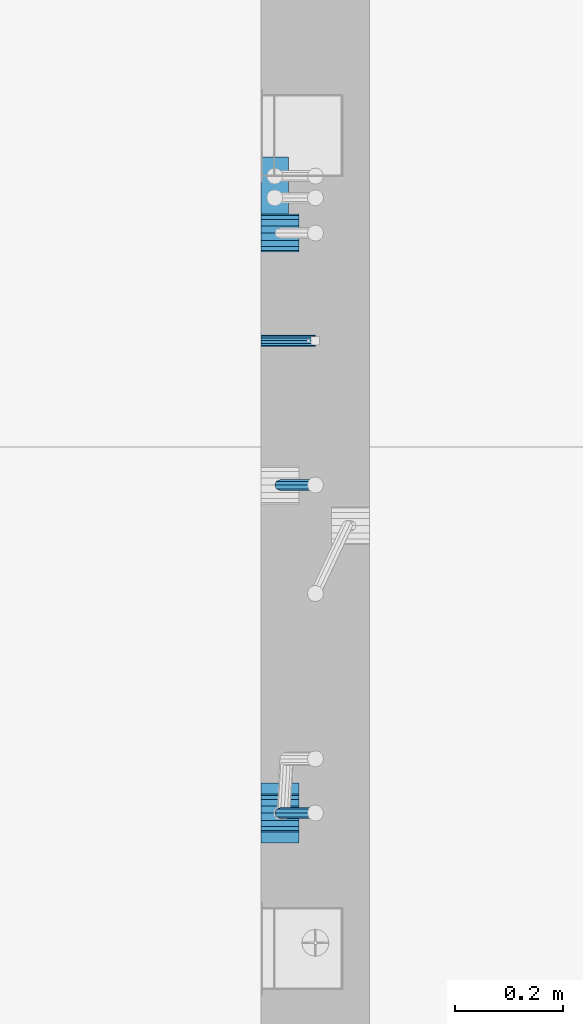
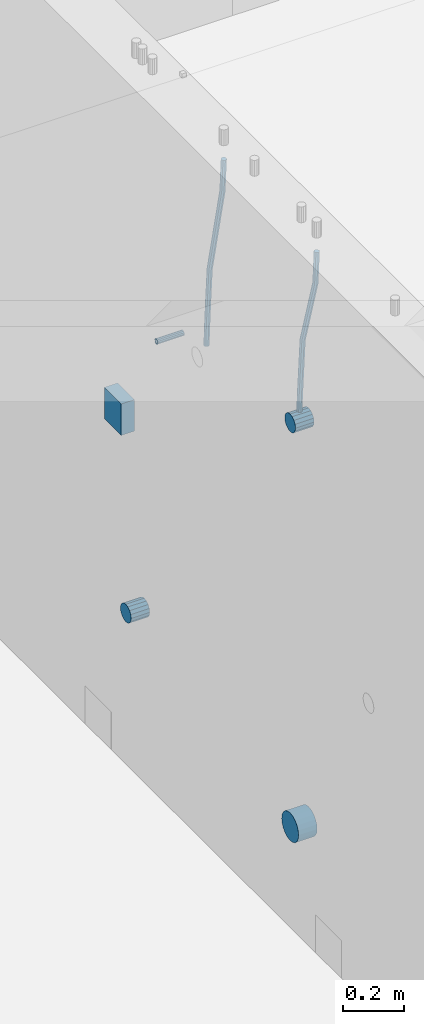
# One storey, part 126 of 325: 7 beams, 2 elements without a shape of their own.
"""IFC2X3 building model written with IfcOpenShell, lengths in millimetres."""

from ifc_helpers import new_model, si_unit, frame, origin_with_axes, place, context, subcontext, project, spatial, faceted_brep, material, type_object, element, aggregate, save


model = new_model("IFC2X3")

# Units and contexts
model_context = context("Model", 3, precision=1e-05, world=origin_with_axes())
body_context = subcontext(model_context, "Body", "Model", "MODEL_VIEW")
ifc_project = project(units=[si_unit("LENGTHUNIT", "METRE", prefix="MILLI"), si_unit("AREAUNIT", "SQUARE_METRE"), si_unit("VOLUMEUNIT", "CUBIC_METRE"), si_unit("MASSUNIT", "GRAM", prefix="KILO"), si_unit("TIMEUNIT", "SECOND"), si_unit("PLANEANGLEUNIT", "RADIAN"), si_unit("SOLIDANGLEUNIT", "STERADIAN"), si_unit("THERMODYNAMICTEMPERATUREUNIT", "DEGREE_CELSIUS"), si_unit("LUMINOUSINTENSITYUNIT", "LUMEN")], contexts=[model_context])

# Site, building, storey
site_placement = place(None, origin_with_axes())
site = spatial("IfcSite", under=ifc_project, at=site_placement, CompositionType="ELEMENT")
building_placement = place(site_placement, origin_with_axes())
building = spatial("IfcBuilding", under=site, at=building_placement, CompositionType="ELEMENT")
storey_placement = place(building_placement, origin_with_axes())
storey = spatial("IfcBuildingStorey", under=building, at=storey_placement, Name="1", CompositionType="ELEMENT", Elevation=0.0)

# Assemblies, beams
assembly_1_placement = place(storey_placement, origin_with_axes())
assembly_1 = element("IfcElementAssembly", 1, at=assembly_1_placement, inside=storey, AssemblyPlace="NOTDEFINED", PredefinedType="REINFORCEMENT_UNIT")
assembly_2_placement = place(assembly_1_placement, origin_with_axes())
assembly_2 = element("IfcElementAssembly", 2, at=assembly_2_placement, Name="Steel Assembly", AssemblyPlace="NOTDEFINED", PredefinedType="RIGID_FRAME")
ifc_material_1 = material(Name="STEEL/Steel_Undefined")
beam_type_1 = type_object("IfcBeamType", PredefinedType="NOTDEFINED")
beam_1_placement = place(assembly_2_placement, frame((21710.0, 11376.2997839591, 83555.0), z_axis=(0.0, 1.0, 0.0), x_axis=(1.0, 0.0, 0.0)))
beam_1 = element("IfcBeam", 3, at=beam_1_placement, type_object=beam_type_1, material=ifc_material_1, Name="M16", context=body_context, shape_type="Brep", body=[
    faceted_brep([(0.0, -8.49999999999272, -1.45519152283669e-11), (0.0, -7.36121593215648, 4.24999999998545), (100.000000000262, -7.36121593215648, 4.24999999998545), (100.000000000262, -8.49999999999272, -1.45519152283669e-11), (0.0, -4.24999999998545, 7.36121593216376), (100.000000000262, -4.24999999998545, 7.36121593216376), (0.0, 1.45519152283669e-11, 8.49999999998545), (100.000000000262, 1.45519152283669e-11, 8.49999999998545), (0.0, 4.25000000001455, 7.36121593216376), (100.000000000262, 4.25000000001455, 7.36121593216376), (0.0, 7.36121593217104, 4.24999999998545), (100.000000000262, 7.36121593217104, 4.24999999998545), (0.0, 8.50000000000728, 0.0), (100.000000000262, 8.50000000000728, 0.0), (0.0, 7.36121593217104, -4.25000000001455), (100.000000000262, 7.36121593217104, -4.25000000001455), (0.0, 4.25000000000728, -7.36121593219286), (100.000000000262, 4.25000000000728, -7.36121593219286), (0.0, 7.27595761418343e-12, -8.5), (100.000000000262, 7.27595761418343e-12, -8.5), (0.0, -4.24999999999272, -7.36121593217831), (100.000000000262, -4.24999999999272, -7.36121593217831), (0.0, -7.36121593215648, -4.25), (100.000000000262, -7.36121593215648, -4.25), (0.0, -10.4999999999927, -1.45519152283669e-11), (0.0, -9.09326673972828, -5.25000000001455), (100.000000000262, -9.09326673972828, -5.25000000001455), (100.000000000262, -10.4999999999927, -1.45519152283669e-11), (0.0, -5.24999999998545, -9.09326673974283), (100.000000000262, -5.24999999998545, -9.09326673974283), (0.0, 7.27595761418343e-12, -10.5), (100.000000000262, 7.27595761418343e-12, -10.5), (0.0, 5.25000000001455, -9.09326673975738), (100.000000000262, 5.25000000001455, -9.09326673975738), (0.0, 9.09326673975011, -5.25000000001455), (100.000000000262, 9.09326673975011, -5.25000000001455), (0.0, 10.5000000000073, -1.45519152283669e-11), (100.000000000262, 10.5000000000073, -1.45519152283669e-11), (0.0, 9.09326673975011, 5.25), (100.000000000262, 9.09326673975011, 5.25), (0.0, 5.25000000000728, 9.09326673972828), (100.000000000262, 5.25000000000728, 9.09326673972828), (0.0, 1.45519152283669e-11, 10.4999999999854), (100.000000000262, 1.45519152283669e-11, 10.4999999999854), (0.0, -5.24999999999272, 9.09326673972828), (100.000000000262, -5.24999999999272, 9.09326673972828), (0.0, -9.09326673972828, 5.24999999998545), (100.000000000262, -9.09326673972828, 5.24999999998545)], [[[0, 1, 2, 3]], [[1, 4, 5, 2]], [[4, 6, 7, 5]], [[6, 8, 9, 7]], [[8, 10, 11, 9]], [[10, 12, 13, 11]], [[12, 14, 15, 13]], [[14, 16, 17, 15]], [[16, 18, 19, 17]], [[18, 20, 21, 19]], [[20, 22, 23, 21]], [[22, 0, 3, 23]], [[24, 25, 26, 27]], [[25, 28, 29, 26]], [[28, 30, 31, 29]], [[30, 32, 33, 31]], [[32, 34, 35, 33]], [[34, 36, 37, 35]], [[36, 38, 39, 37]], [[38, 40, 41, 39]], [[40, 42, 43, 41]], [[42, 44, 45, 43]], [[44, 46, 47, 45]], [[46, 24, 27, 47]], [[29, 31, 33, 35, 37, 39, 41, 43, 45, 47, 27, 26], [5, 7, 9, 11, 13, 15, 17, 19, 21, 23, 3, 2]], [[46, 44, 42, 40, 38, 36, 34, 32, 30, 28, 25, 24], [22, 20, 18, 16, 14, 12, 10, 8, 6, 4, 1, 0]]]),
])
aggregate(assembly_2, [beam_1])
ifc_material_2 = material()
beam_type_2 = type_object("IfcBeamType", Name="D20", PredefinedType="NOTDEFINED")
beam_2_placement = place(assembly_1_placement, frame((21744.9999977209, 10504.9999999961, 83795.0), z_axis=(0.999642804629538, 0.000205762999925497, -0.0267249099901003), x_axis=(0.0267249109941254, -4.30000210532798e-08, 0.999642825779465)))
beam_2 = element("IfcBeam", 4, at=beam_2_placement, type_object=beam_type_2, material=ifc_material_2, Name="JM20", ObjectType="D20", context=body_context, shape_type="Brep", body=[
    faceted_brep([(0.0, -10.0, 0.0), (-4.19531716033816e-08, -7.07106781186667, -7.07106781187031), (60.3902110151248, -7.07106779622882, -7.07106780570393), (60.3902110191848, -9.99999998436397, 6.15546014159918e-09), (0.0, 0.0, -10.0), (60.3902110119234, 1.56360329128802e-08, -9.99999999383726), (4.196772351861e-08, 7.07106781186303, -7.07106781186667), (60.3902110114723, 7.07106782750088, -7.07106780570757), (0.0, 10.0, 0.0), (60.3902110140189, 10.000000015636, 6.15909812040627e-09), (4.196772351861e-08, 7.07106781185939, 7.07106781185939), (60.3902110180788, 7.07106782750088, 7.07106781802213), (0.0, 0.0, 10.0), (60.3902110212803, 1.56378519022837e-08, 10.0000000061627), (-4.19531716033816e-08, -7.07106781187031, 7.07106781185939), (60.3902110217459, -7.07106779622882, 7.07106781802213), (61.0636251037213, -7.07106779605601, -7.07106780563481), (60.991799419251, -9.99999998403655, 6.21366780251265e-09), (61.0933608038758, 1.58179318532348e-08, -9.99999999376814), (61.0635953103047, 7.07106782767551, -7.07106780563481), (60.9917724058905, 10.0000000159635, 6.21366780251265e-09), (60.9199467214348, 7.07106782763913, 7.07106781808034), (60.8902110212803, 1.57651811605319e-08, 10.0000000062137), (60.919976514866, -7.07106779609421, 7.07106781808034), (61.736900248201, -7.07106495914195, -7.05738882369405), (61.5932788141945, -9.99999744984598, 0.0122201548947487), (61.7963655163912, 2.97800033877138e-06, -9.98571699394597), (61.7368406711612, 7.07107066446406, -7.05738942880998), (61.5931945595512, 10.0000025499758, 0.0122192991293559), (61.4495731255302, 7.07107005927173, 7.0818282777218), (61.3901078573399, 2.12213126360439e-06, 10.0101564479701), (61.4496327025554, -7.07106556433428, 7.08182888283409), (278.724613209561, -7.07015065944142, -2.64883307638229), (278.580991775569, -9.99908315014545, 4.42077590220288), (278.78407847778, 0.000917277700864361, -5.57716124663784), (278.724553632535, 7.07198496416277, -2.64883368149822), (278.580907520925, 10.0009168496781, 4.42077504644112), (278.437286086933, 7.07198435897226, 11.4903840250299), (278.377820818714, 0.000916421833608183, 14.4187121952782), (278.437345663944, -7.07015126463193, 11.4903846301422), (280.757740145142, -7.07014209265617, -2.60752588292962), (279.97914288567, -9.99907725889352, 4.4491822438722), (281.080112136013, 0.000926952270674519, -5.53051255744504), (280.757417718196, 7.07199352984026, -2.60753182838744), (279.978686905117, 10.0009227393621, 4.44917383572465), (279.200089645645, 7.0719875731229, 11.5058819625192), (278.877717654759, 0.000918528197871638, 14.4288686370419), (279.200412072576, -7.07014804937353, 11.5058879079807), (282.750959243713, -7.07005867588668, -2.20455064874841), (281.349849970706, -9.99901989442333, 4.72630231008952), (283.331077414448, 0.00102115578738449, -5.07542798552822), (282.750379126286, 7.07207693582313, -2.20460869228191), (281.349029560777, 10.0009800885819, 4.72622022413998), (279.947920287756, 7.07201887003976, 11.6570731829706), (279.367802117034, 0.000939038367505418, 14.5279505197614), (279.948500405197, -7.07011674167188, 11.6571312265078), (490.42756900216, -7.06136735270411, 39.782068138702), (489.026459729153, -9.99032857123893, 46.7129210975436), (491.007687172896, 0.00971247897177818, 36.9111908019222), (490.426988884734, 7.08076825901298, 39.7820100951685), (489.02563931921, 10.0096714117662, 46.7128390115868), (487.624530046218, 7.08071019322961, 53.6436919704247), (487.044411875468, 0.0096303615537181, 56.5145693072081), (487.625110163644, -7.06142541848567, 53.6437500139618), (491.139936791646, -7.06133753991526, 39.9260897251916), (490.366909417033, -9.99027247305094, 46.9839239327412), (491.497771635157, 0.00973298914141196, 37.0102726846344), (491.230799149358, 7.08080189869361, 39.9445188880345), (490.495408195638, 10.0097329219989, 47.0099867047757), (489.722380821026, 7.08079798886138, 54.0678209123216), (489.3645459775, 0.00972745980288892, 56.9836379528824), (489.631518463313, -7.06134144974749, 54.0493917494787), (491.866591294849, -7.07081326331172, 39.9357607788479), (491.734242157807, -10.008102771757, 47.0021217808862), (491.997684863585, 0.00321401835935831, 37.0169260358998), (492.050730029368, 7.07010983225518, 39.955431358132), (491.994653653514, 9.99018245447223, 47.0299401808879), (491.862304516457, 7.05289294603062, 54.0963011829335), (491.731210947721, -0.0211343356422731, 57.0151359258853), (491.678165781937, -7.08803014953628, 54.0766306036494), (512.839658019177, -7.34430634461387, 40.2148915801045), (512.707308882134, -10.2815958530537, 47.2812525821391), (512.970751587927, -0.270279062942791, 37.2960568371527), (513.023796753681, 6.79661675095485, 40.2345621593813), (512.967720377841, 9.7166893731719, 47.3090709821408), (512.835371240784, 6.77939986473211, 54.3754319841792), (512.704277672048, -0.294627416940784, 57.2942667271309), (512.651232506279, -7.36152323083843, 54.3557614048987), (513.475023168634, -7.35259163615956, 40.2233476626352), (513.367394028246, -10.2902034984181, 47.2900376634097), (513.548964110931, -0.277819072547572, 37.3037522746854), (513.54590325398, 6.78980837536619, 40.2415108811765), (513.467633606255, 9.71017040238803, 47.3157243334063), (513.360004465882, 6.77255854013129, 54.3824143341844), (513.28606352357, -0.302214023480701, 57.3020097221342), (513.289124380535, -7.36984147139265, 54.3642511156468), (514.110442121717, -7.35071708105352, 40.2316099536038), (514.027534909808, -10.2882349910469, 47.298629034136), (514.127225867254, -0.276123320652914, 37.311252921696), (514.068054455944, 6.79134521359629, 40.248263480742), (513.967589697961, 9.71166130597521, 47.3221806780894), (513.884682486052, 6.77414339598363, 54.3891997586288), (513.8678987405, -0.300450364420612, 57.309556790533), (513.927070151825, -7.36791889866981, 54.3725462314869), (614.131230002764, -7.05245493793518, 41.5289880054152), (614.048322790841, -9.98997284792858, 48.596007085951), (614.148013748316, 0.022138822467241, 38.608630973511), (614.088842336976, 7.08960735671644, 41.5456415325607), (613.988377579022, 10.0099234490935, 48.6195587299044), (613.905470367114, 7.07240553910196, 55.6865778104475), (613.888686621562, -0.00218822130045737, 58.6069348423516), (613.947858032887, -7.06965675554966, 55.6699242832983)], [[[0, 1, 2, 3]], [[1, 4, 5, 2]], [[4, 6, 7, 5]], [[6, 8, 9, 7]], [[8, 10, 11, 9]], [[10, 12, 13, 11]], [[12, 14, 15, 13]], [[14, 0, 3, 15]], [[14, 12, 10, 8, 6, 4, 1, 0]], [[3, 2, 16, 17]], [[2, 5, 18, 16]], [[5, 7, 19, 18]], [[7, 9, 20, 19]], [[9, 11, 21, 20]], [[11, 13, 22, 21]], [[13, 15, 23, 22]], [[15, 3, 17, 23]], [[17, 16, 24, 25]], [[16, 18, 26, 24]], [[18, 19, 27, 26]], [[19, 20, 28, 27]], [[20, 21, 29, 28]], [[21, 22, 30, 29]], [[22, 23, 31, 30]], [[23, 17, 25, 31]], [[25, 24, 32, 33]], [[24, 26, 34, 32]], [[26, 27, 35, 34]], [[27, 28, 36, 35]], [[28, 29, 37, 36]], [[29, 30, 38, 37]], [[30, 31, 39, 38]], [[31, 25, 33, 39]], [[33, 32, 40, 41]], [[32, 34, 42, 40]], [[34, 35, 43, 42]], [[35, 36, 44, 43]], [[36, 37, 45, 44]], [[37, 38, 46, 45]], [[38, 39, 47, 46]], [[39, 33, 41, 47]], [[41, 40, 48, 49]], [[40, 42, 50, 48]], [[42, 43, 51, 50]], [[43, 44, 52, 51]], [[44, 45, 53, 52]], [[45, 46, 54, 53]], [[46, 47, 55, 54]], [[47, 41, 49, 55]], [[49, 48, 56, 57]], [[48, 50, 58, 56]], [[50, 51, 59, 58]], [[51, 52, 60, 59]], [[52, 53, 61, 60]], [[53, 54, 62, 61]], [[54, 55, 63, 62]], [[55, 49, 57, 63]], [[57, 56, 64, 65]], [[56, 58, 66, 64]], [[58, 59, 67, 66]], [[59, 60, 68, 67]], [[60, 61, 69, 68]], [[61, 62, 70, 69]], [[62, 63, 71, 70]], [[63, 57, 65, 71]], [[65, 64, 72, 73]], [[64, 66, 74, 72]], [[66, 67, 75, 74]], [[67, 68, 76, 75]], [[68, 69, 77, 76]], [[69, 70, 78, 77]], [[70, 71, 79, 78]], [[71, 65, 73, 79]], [[73, 72, 80, 81]], [[72, 74, 82, 80]], [[74, 75, 83, 82]], [[75, 76, 84, 83]], [[76, 77, 85, 84]], [[77, 78, 86, 85]], [[78, 79, 87, 86]], [[79, 73, 81, 87]], [[81, 80, 88, 89]], [[80, 82, 90, 88]], [[82, 83, 91, 90]], [[83, 84, 92, 91]], [[84, 85, 93, 92]], [[85, 86, 94, 93]], [[86, 87, 95, 94]], [[87, 81, 89, 95]], [[89, 88, 96, 97]], [[88, 90, 98, 96]], [[90, 91, 99, 98]], [[91, 92, 100, 99]], [[92, 93, 101, 100]], [[93, 94, 102, 101]], [[94, 95, 103, 102]], [[95, 89, 97, 103]], [[97, 96, 104, 105]], [[96, 98, 106, 104]], [[98, 99, 107, 106]], [[99, 100, 108, 107]], [[100, 101, 109, 108]], [[101, 102, 110, 109]], [[102, 103, 111, 110]], [[103, 97, 105, 111]], [[106, 107, 108, 109, 110, 111, 105, 104]]]),
])
beam_3_placement = place(assembly_1_placement, frame((21744.9999977209, 11109.9999999961, 83690.0), z_axis=(0.999642804629538, 0.000205762999925497, -0.0267249099901003), x_axis=(0.0267249109941254, -4.30000210532798e-08, 0.999642825779465)))
beam_3 = element("IfcBeam", 5, at=beam_3_placement, type_object=beam_type_2, material=ifc_material_2, Name="JM20", ObjectType="D20", context=body_context, shape_type="Brep", body=[
    faceted_brep([(0.0, -10.0, 0.0), (-4.19531716033816e-08, -7.07106781186667, -7.07106781187031), (60.4266690400545, -7.0710677960451, -7.07106780570757), (60.4266690441291, -9.99999998418934, 6.15546014159918e-09), (0.0, 0.0, -10.0), (60.426669036824, 1.58106558956206e-08, -9.99999999384454), (4.196772351861e-08, 7.07106781186303, -7.07106781186667), (60.4266690363438, 7.07106782768096, -7.07106780570757), (0.0, 10.0, 0.0), (60.4266690388904, 10.0000000158179, 6.15182216279209e-09), (4.196772351861e-08, 7.07106781185939, 7.07106781185939), (60.4266690429649, 7.07106782768096, 7.07106781802577), (0.0, 0.0, 10.0), (60.4266690461809, 1.58179318532348e-08, 10.0000000061555), (-4.19531716033816e-08, -7.07106781187031, 7.07106781185939), (60.4266690466611, -7.07106779605238, 7.07106781802213), (61.0378400410118, -7.07106779588503, -7.07106780564936), (60.991799419251, -9.99999998403655, 6.21366780251265e-09), (61.0569027789461, 1.5985278878361e-08, -9.99999999378269), (61.0378209396877, 7.07106782784831, -7.07106780564936), (60.9917724058905, 10.0000000159635, 6.21366780251265e-09), (60.9457317841297, 7.07106782781193, 7.0710678180767), (60.9266690461809, 1.59488990902901e-08, 10.0000000062028), (60.9457508854539, -7.07106779591413, 7.0710678180767), (61.6489592143771, -7.07106614513759, -7.06310863441468), (61.5568818710308, -9.9999984576425, 0.00735959856683621), (61.6870830769039, 1.71821739058942e-06, -9.99179257185824), (61.6489210170112, 7.07106947854481, -7.06310888312146), (61.556827851804, 10.0000015422847, 0.00735924683976918), (61.4647505084577, 7.07106922979438, 7.07782747982128), (61.4266266459163, 1.36643211590126e-06, 10.0065114172685), (61.464788705809, -7.07106639389531, 7.07782772852806), (176.543135720174, -7.07075579406956, -5.56673531796696), (176.451058376813, -9.99968810657447, 1.50373291501455), (176.581259582701, 0.000312069292704109, -8.49541925541052), (176.543097522794, 7.07137982961285, -5.56673556667374), (176.451004357587, 10.00031189336, 1.50373256329476), (176.35892701424, 7.07137958085514, 8.57420079627263), (176.320803151699, 0.000311717507429421, 11.5028847337162), (176.358965211621, -7.07075604281999, 8.57420104497578), (177.098753836006, -7.07075429323595, -5.55949898843028), (176.98362511232, -9.99968666800123, 1.510669025065), (177.146421932586, 0.000313595905026887, -8.48805862247536), (177.098706077581, 7.07138133041735, -5.55949936166144), (176.983557571715, 10.0003133318824, 1.51066849724157), (176.868428848029, 7.07138095712435, 8.58083651073321), (176.820760751449, 0.000313067976094317, 11.5093961447819), (176.868476606425, -7.07075466652896, 8.58083688396073), (177.654312950661, -7.07075204110879, -5.54863964998367), (177.516135294456, -9.99968450931192, 1.52107783331303), (177.711524267797, 0.000315886711177882, -8.47701274570863), (177.654255632195, 7.07138358250813, -5.54864021007961), (177.516054233929, 10.0003154905207, 1.5210770412159), (177.377876577739, 7.0713830223176, 8.59079452451624), (177.320665260588, 0.000315094497636892, 11.5191676202448), (177.377933896176, -7.07075260129932, 8.59079508461218), (299.029771459231, -7.07026000924998, -3.17615191846562), (298.89159380304, -9.99919247745311, 3.89356556482744), (299.086982776382, 0.00080791857362783, -6.10452501419059), (299.029714140794, 7.07187561436331, -3.1761524785652), (298.891512742513, 10.0008075223832, 3.89356477273031), (298.753335086294, 7.07187505418005, 10.963282256027), (298.696123769172, 0.000807126352810883, 13.891655351752), (298.75339240476, -7.07026056943323, 10.963282816123), (300.5204182054, -7.07025396646532, -3.14701471758235), (299.971932015731, -9.99918809797782, 3.91468259446992), (300.747514543924, 0.000814650038591935, -6.07206712448169), (300.520191076153, 7.07188165646039, -3.14701859691559), (299.971610806504, 10.0008119008835, 3.91467710826691), (299.423124616849, 7.0718777693728, 10.9763744203192), (299.196028278326, 0.000809152865258511, 13.9014268272185), (299.423351746067, -7.0702578535529, 10.9763782996524), (301.997683885507, -7.07021227996847, -2.94561261413764), (301.042572372782, -9.99915788591352, 4.06064768581928), (302.393140241125, 0.000861087435623631, -5.84771176216236), (301.997288469822, 7.07192333820967, -2.94563943669345), (301.042013170576, 10.0008421062339, 4.0606097529926), (300.086901657865, 7.07189650029068, 11.0668700529459), (299.691445302247, 0.000823132886580424, 13.9689692009706), (300.087297073522, -7.07023911788747, 11.066896875509), (595.247547294217, -7.06193715364316, 37.0344262651415), (594.292435781506, -9.99088275958638, 44.0406865650948), (595.643003649835, 0.00913621376093943, 34.1323271171168), (595.247151878561, 7.08019846453499, 37.0343994425784), (594.291876579315, 10.0091172325574, 44.0406486322681), (593.336765066575, 7.08017162661235, 51.0469089322251), (592.941308710972, 0.00909825921189622, 53.9490080802498), (593.337160482261, -7.06196399156397, 51.0469357547881), (595.874536898147, -7.0619194608189, 37.1199065052715), (595.328959329563, -9.99085351025315, 44.1820003623798), (596.138420673757, 0.00915019377680437, 34.1998694908689), (595.966031119533, 7.08021875036138, 37.132407399582), (595.458351698282, 10.0091501489569, 44.1996792966529), (594.912774129698, 7.08021609952084, 51.2617731537612), (594.648890354089, 0.00914644492513617, 54.1818101681638), (594.821279908327, -7.06192211166126, 51.2492722594543), (596.507216806087, -7.07016973634745, 37.1283268498955), (596.374889946004, -10.0044926596274, 44.1959206657302), (596.638333902185, 0.00263122293472406, 34.2065228421343), (596.691434617649, 7.07075934023669, 37.1420618035991), (596.635413273558, 9.99380102503346, 44.2153448235404), (596.503086413475, 7.05947810175894, 51.2829386393751), (596.371969317406, -0.0133228575232351, 54.2047426471363), (596.318868601928, -7.08145097482702, 51.2692036856752), (617.802075790198, -7.34785905717763, 37.4117403882592), (617.669748930144, -10.282181980454, 44.4793342040939), (617.933192886281, -0.275058097895453, 34.4899363805016), (617.98629360176, 6.79307001940651, 37.4254753419664), (617.930272257669, 9.7161117042051, 44.498758361904), (617.797945397615, 6.78178878092876, 51.5663521777387), (617.666828301532, -0.291012178353412, 54.4881561855073), (617.613727586038, -7.35914029565538, 51.5526172240352), (618.437465979412, -7.3561446753265, 37.4201968040506), (618.329835563593, -10.2907896452944, 44.488119305166), (618.51143976918, -0.28259855563374, 34.4976322753282), (618.508424090105, 6.78626133094076, 37.4324243830088), (618.430185486082, 9.70959273336121, 44.5054117131695), (618.322555070263, 6.77494776339336, 51.5733342142812), (618.248581280495, -0.298598356299408, 54.4958987430036), (618.25159695957, -7.36745824287755, 51.5611066353231), (619.072909978044, -7.35426965608167, 37.428459048002), (618.989977939549, -10.2888211210229, 44.4967101569127), (619.089735886533, -0.2809021629364, 34.5051333804877), (619.030599275982, 6.78779861257681, 37.4391776831617), (618.930141570861, 9.7110836245156, 44.5118685961243), (618.847209532338, 6.77653215957434, 51.5801197050387), (618.830383623877, -0.296835333569106, 54.503445372553), (618.889520234414, -7.36553610908049, 51.569401069879), (719.093697115357, -7.05600751202655, 38.7258370901727), (719.010765076877, -9.9905589769678, 45.7940881990799), (719.110523023846, 0.017359981116897, 35.8025114226548), (719.051386413325, 7.08606075662829, 38.7365557253288), (718.950928708175, 10.0093457685707, 45.809246638295), (718.86799666968, 7.07479430362946, 52.8774977472058), (718.851170761191, 0.00142681048419036, 55.8008234147201), (718.910307371727, -7.06727396502902, 52.8667791120424)], [[[0, 1, 2, 3]], [[1, 4, 5, 2]], [[4, 6, 7, 5]], [[6, 8, 9, 7]], [[8, 10, 11, 9]], [[10, 12, 13, 11]], [[12, 14, 15, 13]], [[14, 0, 3, 15]], [[14, 12, 10, 8, 6, 4, 1, 0]], [[3, 2, 16, 17]], [[2, 5, 18, 16]], [[5, 7, 19, 18]], [[7, 9, 20, 19]], [[9, 11, 21, 20]], [[11, 13, 22, 21]], [[13, 15, 23, 22]], [[15, 3, 17, 23]], [[17, 16, 24, 25]], [[16, 18, 26, 24]], [[18, 19, 27, 26]], [[19, 20, 28, 27]], [[20, 21, 29, 28]], [[21, 22, 30, 29]], [[22, 23, 31, 30]], [[23, 17, 25, 31]], [[25, 24, 32, 33]], [[24, 26, 34, 32]], [[26, 27, 35, 34]], [[27, 28, 36, 35]], [[28, 29, 37, 36]], [[29, 30, 38, 37]], [[30, 31, 39, 38]], [[31, 25, 33, 39]], [[33, 32, 40, 41]], [[32, 34, 42, 40]], [[34, 35, 43, 42]], [[35, 36, 44, 43]], [[36, 37, 45, 44]], [[37, 38, 46, 45]], [[38, 39, 47, 46]], [[39, 33, 41, 47]], [[41, 40, 48, 49]], [[40, 42, 50, 48]], [[42, 43, 51, 50]], [[43, 44, 52, 51]], [[44, 45, 53, 52]], [[45, 46, 54, 53]], [[46, 47, 55, 54]], [[47, 41, 49, 55]], [[49, 48, 56, 57]], [[48, 50, 58, 56]], [[50, 51, 59, 58]], [[51, 52, 60, 59]], [[52, 53, 61, 60]], [[53, 54, 62, 61]], [[54, 55, 63, 62]], [[55, 49, 57, 63]], [[57, 56, 64, 65]], [[56, 58, 66, 64]], [[58, 59, 67, 66]], [[59, 60, 68, 67]], [[60, 61, 69, 68]], [[61, 62, 70, 69]], [[62, 63, 71, 70]], [[63, 57, 65, 71]], [[65, 64, 72, 73]], [[64, 66, 74, 72]], [[66, 67, 75, 74]], [[67, 68, 76, 75]], [[68, 69, 77, 76]], [[69, 70, 78, 77]], [[70, 71, 79, 78]], [[71, 65, 73, 79]], [[73, 72, 80, 81]], [[72, 74, 82, 80]], [[74, 75, 83, 82]], [[75, 76, 84, 83]], [[76, 77, 85, 84]], [[77, 78, 86, 85]], [[78, 79, 87, 86]], [[79, 73, 81, 87]], [[81, 80, 88, 89]], [[80, 82, 90, 88]], [[82, 83, 91, 90]], [[83, 84, 92, 91]], [[84, 85, 93, 92]], [[85, 86, 94, 93]], [[86, 87, 95, 94]], [[87, 81, 89, 95]], [[89, 88, 96, 97]], [[88, 90, 98, 96]], [[90, 91, 99, 98]], [[91, 92, 100, 99]], [[92, 93, 101, 100]], [[93, 94, 102, 101]], [[94, 95, 103, 102]], [[95, 89, 97, 103]], [[97, 96, 104, 105]], [[96, 98, 106, 104]], [[98, 99, 107, 106]], [[99, 100, 108, 107]], [[100, 101, 109, 108]], [[101, 102, 110, 109]], [[102, 103, 111, 110]], [[103, 97, 105, 111]], [[105, 104, 112, 113]], [[104, 106, 114, 112]], [[106, 107, 115, 114]], [[107, 108, 116, 115]], [[108, 109, 117, 116]], [[109, 110, 118, 117]], [[110, 111, 119, 118]], [[111, 105, 113, 119]], [[113, 112, 120, 121]], [[112, 114, 122, 120]], [[114, 115, 123, 122]], [[115, 116, 124, 123]], [[116, 117, 125, 124]], [[117, 118, 126, 125]], [[118, 119, 127, 126]], [[119, 113, 121, 127]], [[121, 120, 128, 129]], [[120, 122, 130, 128]], [[122, 123, 131, 130]], [[123, 124, 132, 131]], [[124, 125, 133, 132]], [[125, 126, 134, 133]], [[126, 127, 135, 134]], [[127, 121, 129, 135]], [[130, 131, 132, 133, 134, 135, 129, 128]]]),
])
beam_type_3 = type_object("IfcBeamType", Name="D70", PredefinedType="NOTDEFINED")
beam_4_placement = place(assembly_1_placement, frame((21709.9999977209, 10505.0, 83760.0), z_axis=(0.0, 0.0, 1.0), x_axis=(1.0, 0.0, 0.0)))
beam_4 = element("IfcBeam", 6, at=beam_4_placement, type_object=beam_type_3, material=ifc_material_2, ObjectType="D70", context=body_context, shape_type="Brep", body=[
    faceted_brep([(0.0, -35.0, 0.0), (0.0, -32.3357836378964, -13.3939201327739), (70.0, -32.3357836378964, -13.3939201327739), (70.0, -35.0, 0.0), (0.0, -24.7487373415279, -24.7487373415352), (70.0, -24.7487373415279, -24.7487373415352), (0.0, -13.3939201327776, -32.3357836379), (70.0, -13.3939201327776, -32.3357836379), (0.0, 0.0, -35.0), (70.0, 0.0, -35.0), (0.0, 13.3939201327776, -32.3357836379), (70.0, 13.3939201327776, -32.3357836379), (0.0, 24.7487373415279, -24.7487373415352), (70.0, 24.7487373415279, -24.7487373415352), (0.0, 32.3357836378964, -13.3939201327739), (70.0, 32.3357836378964, -13.3939201327739), (0.0, 35.0, 0.0), (70.0, 35.0, 0.0), (0.0, 32.3357836378964, 13.3939201327739), (70.0, 32.3357836378964, 13.3939201327739), (0.0, 24.7487373415279, 24.7487373415352), (70.0, 24.7487373415279, 24.7487373415352), (0.0, 13.3939201327776, 32.3357836379), (70.0, 13.3939201327776, 32.3357836379), (0.0, 0.0, 35.0), (70.0, 0.0, 35.0), (0.0, -13.3939201327776, 32.3357836379), (70.0, -13.3939201327776, 32.3357836379), (0.0, -24.7487373415279, 24.7487373415352), (70.0, -24.7487373415279, 24.7487373415352), (0.0, -32.3357836378964, 13.3939201327739), (70.0, -32.3357836378964, 13.3939201327739)], [[[0, 1, 2, 3]], [[1, 4, 5, 2]], [[4, 6, 7, 5]], [[6, 8, 9, 7]], [[8, 10, 11, 9]], [[10, 12, 13, 11]], [[12, 14, 15, 13]], [[14, 16, 17, 15]], [[16, 18, 19, 17]], [[18, 20, 21, 19]], [[20, 22, 23, 21]], [[22, 24, 25, 23]], [[24, 26, 27, 25]], [[26, 28, 29, 27]], [[28, 30, 31, 29]], [[30, 0, 3, 31]], [[5, 7, 9, 11, 13, 15, 17, 19, 21, 23, 25, 27, 29, 31, 3, 2]], [[30, 28, 26, 24, 22, 20, 18, 16, 14, 12, 10, 8, 6, 4, 1, 0]]]),
])
beam_5_placement = place(assembly_1_placement, frame((21709.9999977209, 11575.0, 82355.0), z_axis=(0.0, 0.0, 1.0), x_axis=(1.0, 0.0, 0.0)))
beam_5 = element("IfcBeam", 7, at=beam_5_placement, type_object=beam_type_3, material=ifc_material_2, ObjectType="D70", context=body_context, shape_type="Brep", body=[
    faceted_brep([(0.0, -35.0, 0.0), (0.0, -32.3357836378964, -13.3939201327739), (70.0, -32.3357836378964, -13.3939201327739), (70.0, -35.0, 0.0), (0.0, -24.7487373415279, -24.7487373415352), (70.0, -24.7487373415279, -24.7487373415352), (0.0, -13.3939201327776, -32.3357836379), (70.0, -13.3939201327776, -32.3357836379), (0.0, 0.0, -35.0), (70.0, 0.0, -35.0), (0.0, 13.3939201327776, -32.3357836379), (70.0, 13.3939201327776, -32.3357836379), (0.0, 24.7487373415279, -24.7487373415352), (70.0, 24.7487373415279, -24.7487373415352), (0.0, 32.3357836378964, -13.3939201327739), (70.0, 32.3357836378964, -13.3939201327739), (0.0, 35.0, 0.0), (70.0, 35.0, 0.0), (0.0, 32.3357836378964, 13.3939201327739), (70.0, 32.3357836378964, 13.3939201327739), (0.0, 24.7487373415279, 24.7487373415352), (70.0, 24.7487373415279, 24.7487373415352), (0.0, 13.3939201327776, 32.3357836379), (70.0, 13.3939201327776, 32.3357836379), (0.0, 0.0, 35.0), (70.0, 0.0, 35.0), (0.0, -13.3939201327776, 32.3357836379), (70.0, -13.3939201327776, 32.3357836379), (0.0, -24.7487373415279, 24.7487373415352), (70.0, -24.7487373415279, 24.7487373415352), (0.0, -32.3357836378964, 13.3939201327739), (70.0, -32.3357836378964, 13.3939201327739)], [[[0, 1, 2, 3]], [[1, 4, 5, 2]], [[4, 6, 7, 5]], [[6, 8, 9, 7]], [[8, 10, 11, 9]], [[10, 12, 13, 11]], [[12, 14, 15, 13]], [[14, 16, 17, 15]], [[16, 18, 19, 17]], [[18, 20, 21, 19]], [[20, 22, 23, 21]], [[22, 24, 25, 23]], [[24, 26, 27, 25]], [[26, 28, 29, 27]], [[28, 30, 31, 29]], [[30, 0, 3, 31]], [[5, 7, 9, 11, 13, 15, 17, 19, 21, 23, 25, 27, 29, 31, 3, 2]], [[30, 28, 26, 24, 22, 20, 18, 16, 14, 12, 10, 8, 6, 4, 1, 0]]]),
])
beam_type_4 = type_object("IfcBeamType", Name="D110", PredefinedType="NOTDEFINED")
beam_6_placement = place(assembly_1_placement, frame((21709.9999977209, 10505.0, 82155.0), z_axis=(0.0, 0.0, 1.0), x_axis=(1.0, 0.0, 0.0)))
beam_6 = element("IfcBeam", 8, at=beam_6_placement, type_object=beam_type_4, material=ifc_material_2, ObjectType="D110", context=body_context, shape_type="Brep", body=[
    faceted_brep([(0.0, -55.0, 0.0), (0.0, -52.3081083962352, -16.9959346906253), (70.0, -52.3081083962352, -16.9959346906253), (70.0, -55.0, 0.0), (0.0, -44.4959346906217, -32.328188876083), (70.0, -44.4959346906217, -32.328188876083), (0.0, -32.3281888760866, -44.4959346906253), (70.0, -32.3281888760866, -44.4959346906253), (0.0, -16.9959346906217, -52.3081083962315), (70.0, -16.9959346906217, -52.3081083962315), (0.0, 0.0, -55.0), (70.0, 0.0, -55.0), (0.0, 16.9959346906217, -52.3081083962315), (70.0, 16.9959346906217, -52.3081083962315), (0.0, 32.3281888760866, -44.4959346906253), (70.0, 32.3281888760866, -44.4959346906253), (0.0, 44.4959346906217, -32.328188876083), (70.0, 44.4959346906217, -32.328188876083), (0.0, 52.3081083962352, -16.9959346906253), (70.0, 52.3081083962352, -16.9959346906253), (0.0, 55.0, 0.0), (70.0, 55.0, 0.0), (0.0, 52.3081083962352, 16.9959346906253), (70.0, 52.3081083962352, 16.9959346906253), (0.0, 44.4959346906217, 32.328188876083), (70.0, 44.4959346906217, 32.328188876083), (0.0, 32.3281888760866, 44.4959346906253), (70.0, 32.3281888760866, 44.4959346906253), (0.0, 16.9959346906217, 52.3081083962315), (70.0, 16.9959346906217, 52.3081083962315), (0.0, 0.0, 55.0), (70.0, 0.0, 55.0), (0.0, -16.9959346906217, 52.3081083962315), (70.0, -16.9959346906217, 52.3081083962315), (0.0, -32.3281888760866, 44.4959346906253), (70.0, -32.3281888760866, 44.4959346906253), (0.0, -44.4959346906217, 32.328188876083), (70.0, -44.4959346906217, 32.328188876083), (0.0, -52.3081083962352, 16.9959346906253), (70.0, -52.3081083962352, 16.9959346906253)], [[[0, 1, 2, 3]], [[1, 4, 5, 2]], [[4, 6, 7, 5]], [[6, 8, 9, 7]], [[8, 10, 11, 9]], [[10, 12, 13, 11]], [[12, 14, 15, 13]], [[14, 16, 17, 15]], [[16, 18, 19, 17]], [[18, 20, 21, 19]], [[20, 22, 23, 21]], [[22, 24, 25, 23]], [[24, 26, 27, 25]], [[26, 28, 29, 27]], [[28, 30, 31, 29]], [[30, 32, 33, 31]], [[32, 34, 35, 33]], [[34, 36, 37, 35]], [[36, 38, 39, 37]], [[38, 0, 3, 39]], [[5, 7, 9, 11, 13, 15, 17, 19, 21, 23, 25, 27, 29, 31, 33, 35, 37, 39, 3, 2]], [[38, 36, 34, 32, 30, 28, 26, 24, 22, 20, 18, 16, 14, 12, 10, 8, 6, 4, 1, 0]]]),
])
beam_type_5 = type_object("IfcBeamType", Name="125X50", PredefinedType="NOTDEFINED")
beam_7_placement = place(assembly_1_placement, frame((21735.0, 11715.0, 83105.0), z_axis=(0.0, 0.0, 1.0), x_axis=(0.0, -1.0, 0.0)))
beam_7 = element("IfcBeam", 9, at=beam_7_placement, type_object=beam_type_5, material=ifc_material_2, Name="WM2", ObjectType="125X50", context=body_context, shape_type="Brep", body=[
    faceted_brep([(0.0, 25.0, -62.5), (0.0, 25.0, 62.5), (110.0, 25.0, 62.5), (110.0, 25.0, -62.5), (0.0, -25.0, 62.5), (110.0, -25.0, 62.5), (0.0, -25.0, -62.5), (110.0, -25.0, -62.5)], [[[0, 1, 2, 3]], [[1, 4, 5, 2]], [[4, 6, 7, 5]], [[6, 0, 3, 7]], [[5, 7, 3, 2]], [[0, 6, 4, 1]]]),
])
aggregate(assembly_1, [beam_2, beam_4, assembly_2, beam_7, beam_5, beam_3, beam_6])

save(model, "model.ifc")
